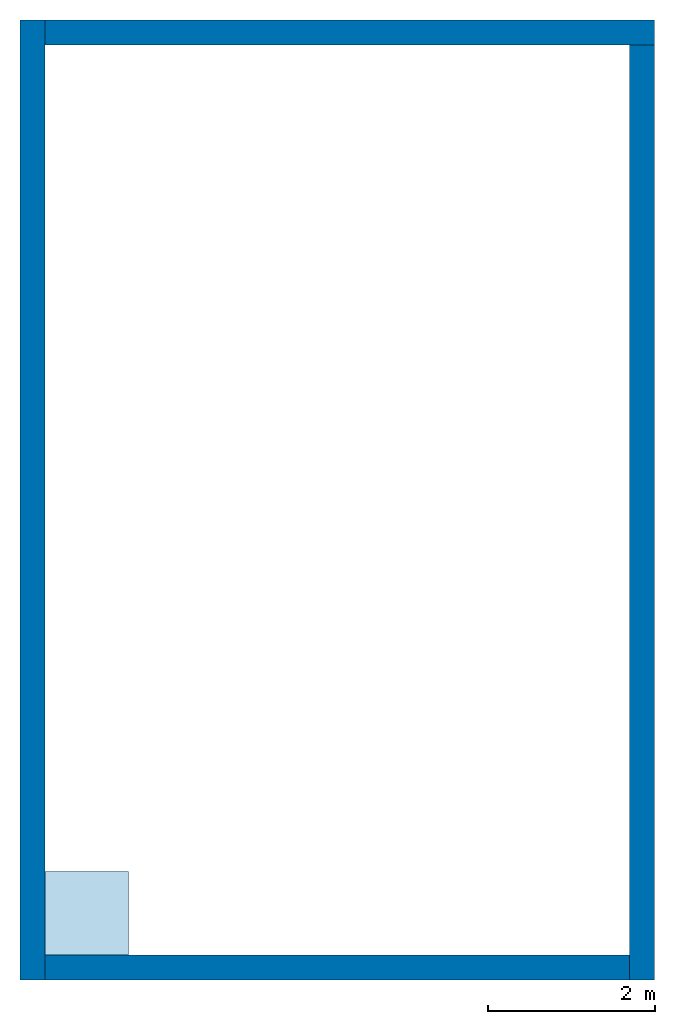
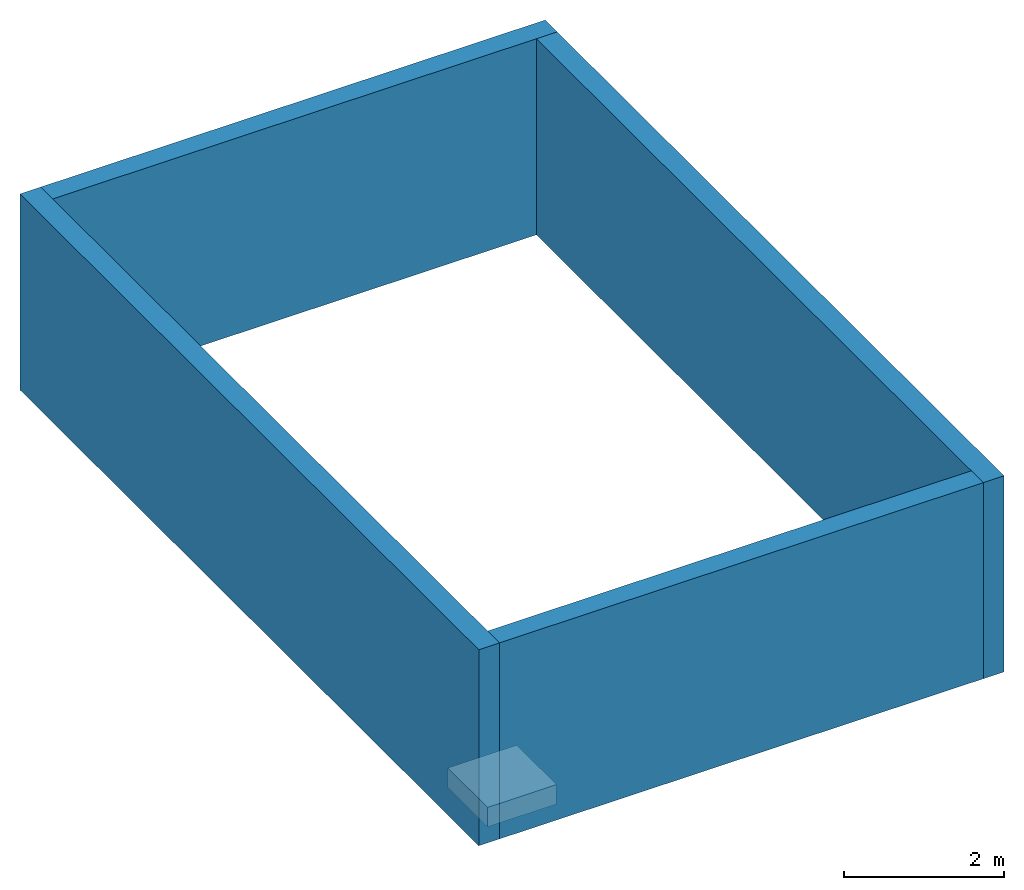
# One storey: 4 walls, 1 slab.
"""IFC4 building model written with IfcOpenShell, lengths in metres."""

from ifc_helpers import new_model, entity, si_unit, converted_unit, frame, origin_with_axes, origin_2d_with_axis, place, context, subcontext, project, spatial, line, indexed_curve, outline, extrude, material, layer, layer_set, layer_usage, type_object, element, save


model = new_model("IFC4")

# Units and contexts
model_context = context("Model", 3, precision=1e-05, world=origin_with_axes())
plan_context = context("Plan", 2, precision=1e-05, world=origin_2d_with_axis())
body_context = subcontext(model_context, "Body", "Model", "MODEL_VIEW")
ifc_project = project(units=[si_unit("LENGTHUNIT", "METRE"), converted_unit("PLANEANGLEUNIT", "degree", entity("IfcReal", 0.0174532925199433), si_unit("PLANEANGLEUNIT", "RADIAN"), dimensions=[0, 0, 0, 0, 0, 0, 0]), si_unit("AREAUNIT", "SQUARE_METRE"), si_unit("VOLUMEUNIT", "CUBIC_METRE")], contexts=[model_context, plan_context])

# Site, building, storey
site_placement = place(None, frame((0.0, 0.0, -1.5), z_axis=(0.0, 0.0, 1.0), x_axis=(1.0, 0.0, 0.0)))
site = spatial("IfcSite", under=ifc_project, at=site_placement)
building_placement = place(site_placement, origin_with_axes())
building = spatial("IfcBuilding", under=site, at=building_placement, Name="Building")
storey_placement = place(building_placement, origin_with_axes())
storey = spatial("IfcBuildingStorey", under=building, at=storey_placement, Name="Storey")

# Slab
ifc_material = material()
ifc_layer_1 = layer(ifc_material, 0.3)
ifc_layer_set_1 = layer_set([ifc_layer_1])
ifc_layer_usage_1 = layer_usage(ifc_layer_set_1, "AXIS3", "POSITIVE", 0.0)
slab_type = type_object("IfcSlabType", Name="FLR250", PredefinedType="NOTDEFINED", material=ifc_layer_set_1)
slab_placement = place(storey_placement, frame((0.0, 0.0, -0.299999952316284), z_axis=(0.0, 0.0, 1.0), x_axis=(1.0, 0.0, 0.0)))
element("IfcSlab", 1, at=slab_placement, inside=storey, type_object=slab_type, material=ifc_layer_usage_1, Name="Slab", context=body_context, shape_type="SweptSolid", body=[
    extrude(outline(indexed_curve([(0.0, 0.0), (0.0, 1.0), (1.0, 1.0), (1.0, 0.0)], segments=[line(4, 1), line(1, 2), line(2, 3), line(3, 4)], self_intersect=False)), None, (0.0, 0.0, 1.0), 0.3),
])

# Walls
ifc_layer_2 = layer(ifc_material, 0.3)
ifc_layer_set_2 = layer_set([ifc_layer_2])
ifc_layer_usage_2 = layer_usage(ifc_layer_set_2, "AXIS2", "POSITIVE", 0.0)
wall_type = type_object("IfcWallType", Name="WAL300", PredefinedType="NOTDEFINED", material=ifc_layer_set_2)
wall_1_placement = place(storey_placement, frame((0.0, -0.300000190734863, -0.299999952316284), z_axis=(0.0, 0.0, 1.0), x_axis=(1.0, 0.0, 0.0)))
element("IfcWall", 2, at=wall_1_placement, inside=storey, type_object=wall_type, material=ifc_layer_usage_2, Name="Wall", context=body_context, shape_type="SweptSolid", body=[
    extrude(outline(indexed_curve([(0.0, 0.0), (0.0, 0.3), (7.0, 0.3), (7.0, 0.0), (0.0, 0.0)], self_intersect=False)), origin_with_axes(), (0.0, 0.0, 1.0), 3.0),
])
ifc_layer_usage_3 = layer_usage(ifc_layer_set_2, "AXIS2", "POSITIVE", 0.0)
wall_2_placement = place(storey_placement, frame((7.00000476837158, 10.8999996185303, -0.299999952316284), z_axis=(0.0, 0.0, 1.0), x_axis=(-2.82129974493717e-07, -0.99999999999996, 0.0)))
element("IfcWall", 3, at=wall_2_placement, inside=storey, type_object=wall_type, material=ifc_layer_usage_3, Name="Wall", context=body_context, shape_type="SweptSolid", body=[
    extrude(outline(indexed_curve([(0.0, 0.0), (0.0, 0.3), (11.1999997683946, 0.3), (11.1999997683946, 0.0), (0.0, 0.0)], self_intersect=False)), origin_with_axes(), (0.0, 0.0, 1.0), 3.0),
])
ifc_layer_usage_4 = layer_usage(ifc_layer_set_2, "AXIS2", "POSITIVE", 0.0)
wall_3_placement = place(storey_placement, frame((7.29999971389771, 11.1999998092651, -0.299999952316284), z_axis=(0.0, 0.0, 1.0), x_axis=(-0.999999999999989, 1.50995802528085e-07, 0.0)))
element("IfcWall", 4, at=wall_3_placement, inside=storey, type_object=wall_type, material=ifc_layer_usage_4, Name="Wall", context=body_context, shape_type="SweptSolid", body=[
    extrude(outline(indexed_curve([(0.0, 0.0), (0.0, 0.3), (7.29999980142671, 0.3), (7.29999980142671, 0.0), (0.0, 0.0)], self_intersect=False)), origin_with_axes(), (0.0, 0.0, 1.0), 3.0),
])
ifc_layer_usage_5 = layer_usage(ifc_layer_set_2, "AXIS2", "POSITIVE", 0.0)
wall_4_placement = place(storey_placement, frame((-0.300000011920929, 11.1999998092651, -0.299999952316284), z_axis=(0.0, 0.0, 1.0), x_axis=(7.54979012640431e-08, -0.999999999999997, 0.0)))
element("IfcWall", 5, at=wall_4_placement, inside=storey, type_object=wall_type, material=ifc_layer_usage_5, Name="Wall", context=body_context, shape_type="SweptSolid", body=[
    extrude(outline(indexed_curve([(0.0, 0.0), (0.0, 0.3), (11.5, 0.3), (11.5, 0.0), (0.0, 0.0)], self_intersect=False)), origin_with_axes(), (0.0, 0.0, 1.0), 3.0),
])

save(model, "model.ifc")
